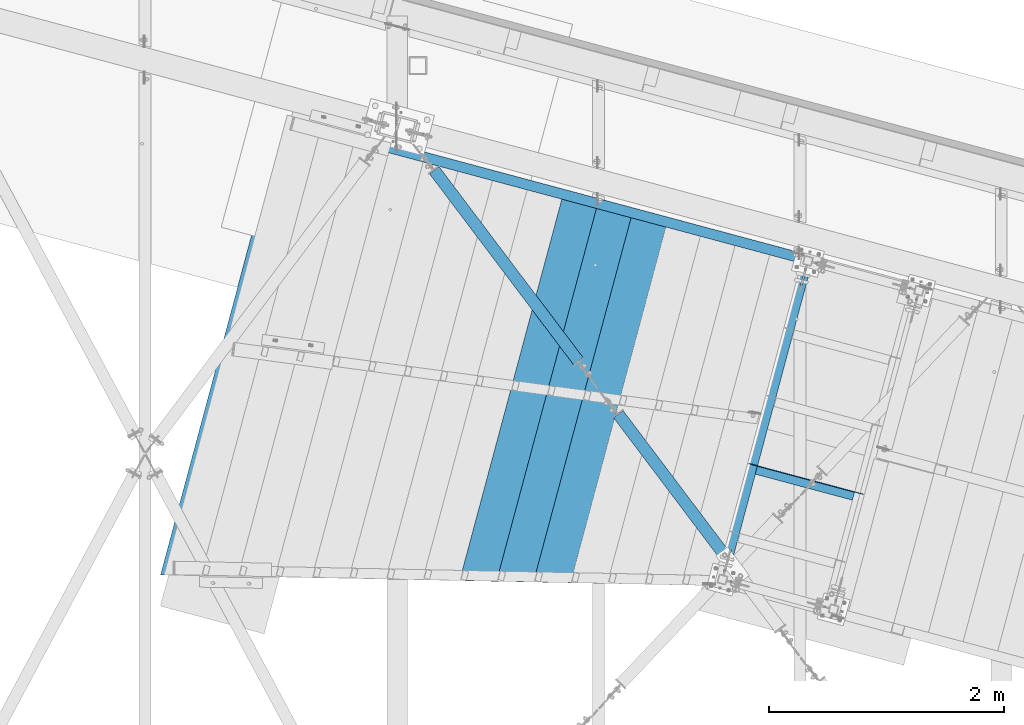
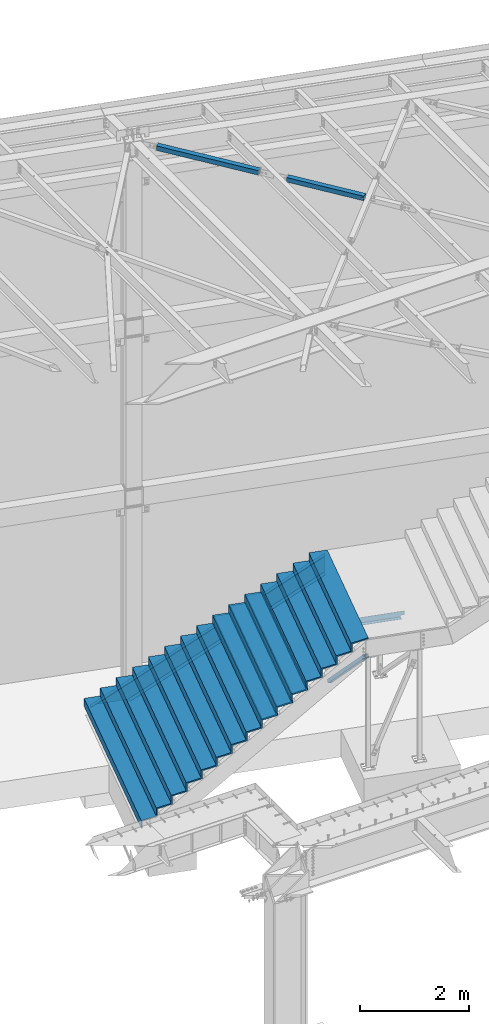
# One storey, part 1172 of 1763: 7 beams, 2 members, 6 elements without a shape of their own.
"""IFC2X3 building model written with IfcOpenShell, lengths in millimetres."""

from ifc_helpers import new_model, si_unit, frame, origin_with_axes, place, context, subcontext, project, spatial, faceted_brep, material, type_object, element, aggregate, save


model = new_model("IFC2X3")

# Units and contexts
model_context = context("Model", 3, precision=1e-05, world=origin_with_axes())
body_context = subcontext(model_context, "Body", "Model", "MODEL_VIEW")
ifc_project = project(units=[si_unit("LENGTHUNIT", "METRE", prefix="MILLI"), si_unit("AREAUNIT", "SQUARE_METRE"), si_unit("VOLUMEUNIT", "CUBIC_METRE"), si_unit("MASSUNIT", "GRAM", prefix="KILO"), si_unit("TIMEUNIT", "SECOND"), si_unit("PLANEANGLEUNIT", "RADIAN"), si_unit("SOLIDANGLEUNIT", "STERADIAN"), si_unit("THERMODYNAMICTEMPERATUREUNIT", "DEGREE_CELSIUS"), si_unit("LUMINOUSINTENSITYUNIT", "LUMEN")], contexts=[model_context])

# Site, building, storey
site_placement = place(None, origin_with_axes())
site = spatial("IfcSite", under=ifc_project, at=site_placement, CompositionType="ELEMENT")
building_placement = place(site_placement, origin_with_axes())
building = spatial("IfcBuilding", under=site, at=building_placement, Name="Undefined", CompositionType="ELEMENT")
storey_placement = place(building_placement, origin_with_axes())
storey = spatial("IfcBuildingStorey", under=building, at=storey_placement, Name="Undefined", CompositionType="ELEMENT", Elevation=0.0)

# Assembly, beam
assembly_1_placement = place(storey_placement, origin_with_axes())
assembly_1 = element("IfcElementAssembly", 1, at=assembly_1_placement, inside=storey, Name="FRAME", AssemblyPlace="NOTDEFINED", PredefinedType="RIGID_FRAME")
ifc_material_1 = material(Name="STEEL/A36")
beam_type_1 = type_object("IfcBeamType", Name="L5X3X1/4", PredefinedType="NOTDEFINED")
beam_1_placement = place(assembly_1_placement, frame((-28140.7287703231, 61498.0014634783, 2311.40000007908), z_axis=(0.0, 0.0, 1.0), x_axis=(0.965913267114843, -0.258865912030785, 0.0)))
beam_1 = element("IfcBeam", 2, at=beam_1_placement, type_object=beam_type_1, material=ifc_material_1, Name="ANGLE", ObjectType="L5X3X1/4", context=body_context, shape_type="Brep", body=[
    faceted_brep([(85.7250002993387, -38.0999999998603, -57.1500000000001), (92.0750017297105, -38.0999999998603, -63.499999957723), (935.037468048155, -38.0999999993292, -63.4999999958368), (941.387469479872, -38.0999999993292, -57.1500001000077), (92.0750019702682, 38.099999999984, -63.5), (935.037468215283, 38.1000000005079, -63.5), (949.227390314394, 31.7500000005311, -26.3667318659031), (949.22739032832, 38.1000000005151, -26.3667318659031), (954.087470019935, 38.1000000005224, -25.4000021055181), (954.087470006009, 31.7500000005311, -25.4000021055181), (945.107213654439, 31.7500000005239, -29.1197457287767), (945.107213668365, 38.1000000005079, -29.1197457287767), (942.354199608213, 31.7500000005239, -33.239922266207), (942.354199622132, 38.1000000005151, -33.239922266207), (941.387469631547, 31.7500000005239, -38.1000019147832), (941.387469645473, 38.1000000005079, -38.1000019147832), (941.387469631416, 31.7500000005239, -57.1500000000001), (941.387469645473, 38.1000000005079, -57.1500001197246), (85.7250005197857, 31.7499999999927, -57.1500000000001), (85.7250005398237, 38.0999999999694, -57.1500000397209), (85.7250005197711, 31.7499999999927, -38.1000018544964), (85.7250005398237, 38.0999999999694, -38.1000018544964), (84.7582705431123, 31.7499999999854, -33.2399222059203), (84.7582705631648, 38.0999999999694, -33.2399222059203), (82.0052564968937, 31.7499999999782, -29.1197456684899), (82.005256516939, 38.0999999999694, -29.1197456684899), (77.8850798369385, 31.7499999999854, -26.3667318056164), (77.8850798569911, 38.0999999999767, -26.3667318056164), (73.0250001453314, 31.7499999999854, -25.4000020452313), (73.0250001653767, 38.0999999999694, -25.4000020452313), (9.52500204597163, 31.7499999999345, -25.4000048709327), (9.52500206602417, 38.0999999999258, -25.4000048709327), (9.52500204597163, 31.7499999999345, 63.5), (9.52500206602417, 38.0999999999258, 63.5), (1017.58746719851, 31.7500000005748, 63.5), (1017.58746721857, 38.1000000005588, 63.5), (1017.58746721857, 38.1000000005588, -25.400004931219), (1017.58746719851, 31.7500000005748, -25.4000049312194)], [[[0, 1, 2, 3]], [[1, 4, 5, 2]], [[6, 7, 8, 9]], [[10, 11, 7, 6]], [[12, 13, 11, 10]], [[14, 15, 13, 12]], [[15, 14, 16, 17]], [[3, 2, 5, 17, 16]], [[18, 0, 3, 16]], [[1, 0, 18, 19, 4]], [[20, 21, 19, 18]], [[22, 23, 21, 20]], [[24, 25, 23, 22]], [[26, 27, 25, 24]], [[28, 29, 27, 26]], [[29, 28, 30, 31]], [[31, 30, 32, 33]], [[33, 32, 34, 35]], [[8, 7, 11, 13, 15, 17, 5, 4, 19, 21, 23, 25, 27, 29, 31, 33, 35, 36]], [[9, 8, 36, 37]], [[32, 30, 28, 26, 24, 22, 20, 18, 16, 14, 12, 10, 6, 9, 37, 34]], [[36, 35, 34, 37]]]),
])
aggregate(assembly_1, [beam_1])

assembly_2_placement = place(storey_placement, origin_with_axes())
assembly_2 = element("IfcElementAssembly", 3, at=assembly_2_placement, inside=storey, Name="H. BRACE", AssemblyPlace="NOTDEFINED", PredefinedType="RIGID_FRAME")
ifc_material_2 = material()
beam_type_2 = type_object("IfcBeamType", Name="HSS4X4X3/8", PredefinedType="NOTDEFINED")
beam_2_placement = place(assembly_2_placement, frame((-28260.020259811, 60661.9278012082, 12371.3875), z_axis=(0.0, 0.0, 1.0), x_axis=(-0.602242336837067, 0.798313326784057, 0.0)))
beam_2 = element("IfcBeam", 4, at=beam_2_placement, type_object=beam_type_2, material=ifc_material_2, Name="H. BRACE", ObjectType="HSS4X4X3/8", context=body_context, shape_type="Brep", body=[
    faceted_brep([(153.987500001618, -50.7999999998865, -6.35000000000036), (153.987500001676, -41.2749999998996, -6.35000000000036), (72.9619621178063, -41.2749999999178, -6.35000000000036), (72.9619621177844, -50.799999999901, -6.35000000000036), (153.987500001618, -50.7999999998865, 6.35000000000036), (153.987500001676, -41.2749999998996, 6.35000000000036), (72.9619621177844, -50.799999999901, 6.35000000000036), (72.9619621178063, -41.2749999999178, 6.35000000000036), (153.9875000022, 41.2749999999687, -6.35000000000036), (153.987500002258, 50.7999999999593, -6.35000000000036), (72.9619621180755, 50.7999999999411, -6.35000000000036), (72.9619621180464, 41.2749999999578, -6.35000000000036), (153.9875000022, 41.2749999999687, 6.35000000000036), (153.987500002258, 50.7999999999593, 6.35000000000036), (72.9619621180464, 41.2749999999578, 6.35000000000036), (72.9619621180755, 50.7999999999411, 6.35000000000036), (72.9619621178063, -41.2749999999178, 41.2749999999996), (72.9619621180464, 41.2749999999578, 41.2749999999996), (1612.38545285382, 41.2750000003216, 41.2749999999996), (1612.38545285357, -41.2749999995503, 41.2749999999996), (72.9619621180755, 50.7999999999411, 50.7999999999993), (1612.38545285384, 50.8000000003049, 50.7999999999993), (1612.38545285384, 50.8000000003049, -50.7999999999993), (72.9619621180755, 50.7999999999411, -50.7999999999993), (72.9619621177844, -50.799999999901, -50.7999999999993), (1612.38545285354, -50.7999999995336, -50.7999999999993), (72.9619621178063, -41.2749999999178, -41.2749999999996), (72.9619621180464, 41.2749999999578, -41.2749999999996), (1612.38545285357, -41.2749999995503, -41.2749999999996), (1612.38545285382, 41.2750000003216, -41.2749999999996), (1612.38545285354, -50.7999999995336, 50.7999999999993), (72.9619621177844, -50.799999999901, 50.7999999999993)], [[[0, 1, 2, 3]], [[4, 5, 1, 0]], [[6, 7, 5, 4]], [[8, 9, 10, 11]], [[12, 13, 9, 8]], [[14, 15, 13, 12]], [[16, 17, 18, 19]], [[20, 21, 22, 23, 10, 9, 13, 15]], [[24, 23, 22, 25]], [[26, 27, 11, 10, 23, 24, 3, 2]], [[16, 19, 28, 26, 2, 1, 5, 7]], [[27, 26, 28, 29]], [[30, 25, 22, 21], [19, 18, 29, 28]], [[20, 31, 30, 21]], [[3, 24, 25, 30, 31, 6, 4, 0]], [[31, 20, 15, 14, 17, 16, 7, 6]], [[11, 27, 29, 18, 17, 14, 12, 8]]]),
])
aggregate(assembly_2, [beam_2])

assembly_3_placement = place(storey_placement, origin_with_axes())
assembly_3 = element("IfcElementAssembly", 5, at=assembly_3_placement, inside=storey, Name="H. BRACE", AssemblyPlace="NOTDEFINED", PredefinedType="RIGID_FRAME")
beam_3_placement = place(assembly_3_placement, frame((-29400.5296174484, 62173.7508063884, 12371.3875), z_axis=(0.0, 0.0, 1.0), x_axis=(-0.602242336837067, 0.798313326784057, 0.0)))
beam_3 = element("IfcBeam", 6, at=beam_3_placement, type_object=beam_type_2, material=ifc_material_2, Name="H. BRACE", ObjectType="HSS4X4X3/8", context=body_context, shape_type="Brep", body=[
    faceted_brep([(281.53394529043, 41.2750000000051, -41.2749999999996), (281.533945290197, -41.2749999998668, -41.2749999999996), (2314.27412926893, -41.2749999993721, -41.2749999999996), (2314.27412926916, 41.2750000004889, -41.2749999999996), (281.533945290197, -41.2749999998668, 41.2749999999996), (2314.27412926893, -41.2749999993721, 41.2749999999996), (281.53394529043, 41.2750000000051, 41.2749999999996), (2314.27412926916, 41.2750000004889, 41.2749999999996), (281.533945290459, 50.7999999999884, -50.7999999999993), (281.533945290459, 50.7999999999884, 50.7999999999993), (2314.27412926919, 50.8000000004831, 50.7999999999993), (2314.27412926919, 50.8000000004831, -50.7999999999993), (281.533945290168, -50.7999999998501, 50.7999999999993), (2314.2741292689, -50.7999999993663, 50.7999999999993), (281.533945290168, -50.7999999998501, -50.7999999999993), (2314.2741292689, -50.7999999993663, -50.7999999999993)], [[[0, 1, 2, 3]], [[1, 4, 5, 2]], [[4, 6, 7, 5]], [[6, 0, 3, 7]], [[8, 9, 10, 11]], [[9, 12, 13, 10]], [[12, 14, 15, 13]], [[14, 8, 11, 15]], [[13, 15, 11, 10], [5, 7, 3, 2]], [[14, 12, 9, 8], [6, 4, 1, 0]]]),
])
aggregate(assembly_3, [beam_3])

# Assembly, member
assembly_4_placement = place(storey_placement, origin_with_axes())
assembly_4 = element("IfcElementAssembly", 7, at=assembly_4_placement, inside=storey, Name="STRINGER", AssemblyPlace="NOTDEFINED", PredefinedType="RIGID_FRAME")
member_type_1 = type_object("IfcMemberType", Name="C15X33.9", PredefinedType="NOTDEFINED")
member_1_placement = place(assembly_4_placement, frame((-27587.7807470832, 63251.1006457711, 2442.12511935681), z_axis=(0.486695708763338, -0.13043503320458, -0.863778900636194), x_axis=(-0.834335499956352, 0.223602912988303, -0.50387102597364)))
member_1 = element("IfcMember", 8, at=member_1_placement, type_object=member_type_1, material=ifc_material_1, Name="STRINGER", ObjectType="C15X33.9", context=body_context, shape_type="Brep", body=[
    faceted_brep([(-3.47911372537055, -42.8624999996318, -190.49999999988), (1.61578232239117, -42.8624999996682, -181.765892499887), (9.02115236152167, 33.3375000004598, -169.070972499881), (196.545886544038, 33.3374999991574, 152.399999999587), (201.016754472439, 33.3374999991283, 160.064345010509), (206.270620514268, 33.337499999092, 169.070972500009), (213.675990492862, -42.8625000011161, 181.765892499996), (218.770886540624, -42.8625000011598, 190.499999999993), (218.770886574683, 42.8624999990352, 190.500000000004), (-3.47911369131907, 42.8625000005704, -190.499999999876), (5154.39440455224, -42.8625000138563, -190.499999996955), (5139.42164885585, -42.8625000138345, -181.765892496969), (5117.65892881748, 33.3374999863663, -169.070972496982), (4537.98702379651, 33.3374999871448, 169.070972502464), (4516.22430388694, -42.8625000129832, 181.765892502437), (4501.25154819057, -42.8625000129759, 190.500000002419), (4501.2515481181, 42.8624999872263, 190.50000000243), (5154.39440447977, 42.8624999863387, -190.499999996948)], [[[0, 1, 2, 3, 4, 5, 6, 7, 8, 9]], [[1, 0, 10, 11]], [[2, 1, 11, 12]], [[5, 4, 3, 2, 12, 13]], [[6, 5, 13, 14]], [[7, 6, 14, 15]], [[8, 7, 15, 16]], [[9, 8, 16, 17]], [[15, 14, 13, 12, 11, 10, 17, 16]], [[0, 9, 17, 10]]]),
])

assembly_5_placement = place(storey_placement, origin_with_axes())
assembly_5 = element("IfcElementAssembly", 9, at=assembly_5_placement, inside=storey, Name="BRACE", AssemblyPlace="NOTDEFINED", PredefinedType="RIGID_FRAME")
member_type_2 = type_object("IfcMemberType", Name="HSS3X3X1/4", PredefinedType="NOTDEFINED")
member_2_placement = place(assembly_5_placement, frame((-27619.8997057889, 63251.3629503325, -254.000000011885), z_axis=(0.172357044040262, 0.643130363150223, 0.746107489148826), x_axis=(-0.193141324899824, -0.720675248626209, 0.66582551365466)))
member_2 = element("IfcMember", 10, at=member_2_placement, type_object=member_type_2, material=ifc_material_2, Name="BRACE", ObjectType="HSS3X3X1/4", context=body_context, shape_type="Brep", body=[
    faceted_brep([(3638.34189830234, 6.35008143950108, 38.1000000056956), (3431.96689252929, 6.35008143055165, 38.1000000053609), (3431.96689252927, 6.35006785710721, 31.7500000053769), (3638.34189830413, 6.35006786606391, 31.7500000057044), (3429.53685277032, 5.86671646916511, 38.1000000053609), (3429.53685277032, 5.86670289572794, 31.7500000053769), (3427.47676453633, 4.49020951885905, 38.1000000053609), (3427.47676453632, 4.49019594542187, 31.7500000053697), (3426.10025758616, 2.43012128475675, 38.1000000053609), (3426.10025758616, 2.43010771131958, 31.7500000053769), (3425.61689262495, 8.15303719718941e-05, 38.1000000053609), (3425.61689262494, 6.79569347994402e-05, 31.7500000053769), (3426.10025758628, -2.42995822866214, 38.1000000053609), (3426.10025758627, -2.42997180209932, 31.7500000053769), (3427.47676453656, -4.49004646272078, 38.1000000053682), (3427.47676453656, -4.49006003615068, 31.7500000053842), (3429.53685277066, -5.86655341291771, 38.1000000053755), (3429.53685277066, -5.86656698635488, 31.7500000053842), (3431.96689252968, -6.34991837416601, 38.1000000053828), (3431.96689252967, -6.34993194759591, 31.7500000053915), (3638.34189830262, -6.34991836979316, 38.1000000057174), (3638.34189830442, -6.34993194323761, 31.7500000057262), (3638.34189832208, 6.34993213164853, -31.749999994172), (3431.96689252918, 6.34993212276459, -31.7499999944994), (3431.96689252917, 6.34991854932741, -38.0999999944834), (3638.34189832388, 6.34991855821136, -38.099999994156), (3429.53685277022, 5.86656716137804, -31.7499999945067), (3429.53685277021, 5.86655358794087, -38.0999999944906), (3427.47676453622, 4.49006021107198, -31.7499999944994), (3427.47676453622, 4.4900466376348, -38.0999999944906), (3426.10025758607, 2.42997197696968, -31.7499999945067), (3426.10025758607, 2.42995840353979, -38.0999999944979), (3425.61689262484, -6.77774150972255e-05, -31.7499999945067), (3425.61689262484, -8.13508449937217e-05, -38.0999999944906), (3426.10025758619, -2.43010753644194, -31.7499999944994), (3426.10025758619, -2.43012110988639, -38.0999999944834), (3427.47676453647, -4.49019577050058, -31.7499999944921), (3427.47676453646, -4.49020934393775, -38.0999999944834), (3429.53685277056, -5.86670272070478, -31.7499999944921), (3429.53685277055, -5.86671629414195, -38.0999999944761), (3431.96689252958, -6.3500676819458, -31.7499999944848), (3431.96689252958, -6.35008125538297, -38.0999999944688), (3638.34189832237, -6.35006767763844, -31.7499999941574), (3638.34189832416, -6.35008125108288, -38.0999999941414), (118.968544799733, 31.7499999999782, 31.7500000000873), (118.968544810552, 31.7499999998836, -31.7499999997963), (3638.34189832152, 31.7499999957072, -31.7499999941938), (3638.34189830357, 31.7499999957945, 31.7500000056752), (3638.34189830497, -31.7500000043365, 31.750000005748), (118.968544766285, -31.7500000001601, 31.7500000001601), (118.968544779673, -6.34988402445742, 31.750000000131), (325.343551481637, -6.34992299378791, 31.7500000004584), (327.773591609155, -5.86655837652506, 31.7500000004584), (329.833680250282, -4.49005150574521, 31.7500000004657), (331.210187509649, -2.42996312424657, 31.7500000004657), (331.693552585297, 7.69121252233163e-05, 31.7500000004657), (331.210187737401, 2.43011673642468, 31.7500000004584), (329.833681093718, 4.49020482433843, 31.7500000004511), (327.773593263322, 5.86671185339219, 31.7500000004511), (325.343553869745, 6.35007715583924, 31.7500000004438), (118.968544786359, 6.35011579983984, 31.7500000001164), (118.96854477709, -31.7500000002474, -31.7499999997162), (3638.34189832293, -31.7500000044383, -31.7499999941283), (118.968544797164, 6.34999437355873, -31.7499999997672), (325.343553869468, 6.34995572941261, -31.7499999994325), (327.77359326306, 5.86659042696556, -31.7499999994252), (329.833681093449, 4.49008339790453, -31.7499999994179), (331.210187737131, 2.42999530999077, -31.7499999994179), (331.693552585028, -4.45143086835742e-05, -31.7499999994179), (331.210187509379, -2.43008455068048, -31.7499999994179), (329.833680250013, -4.49017293217912, -31.7499999994179), (327.773591608879, -5.86667980295897, -31.7499999994106), (325.343551481361, -6.35004442022182, -31.7499999994106), (118.96854479047, -6.35000545073126, -31.7499999997381), (118.968544798248, 6.34998223093135, -38.0999999997439), (325.343553869439, 6.34994358677068, -38.0999999994237), (327.773593263031, 5.86657828431635, -38.0999999994165), (329.83368109342, 4.49007125526259, -38.0999999994092), (331.210187737102, 2.42998316734884, -38.0999999994092), (331.693552584999, -5.66569578950293e-05, -38.0999999994092), (331.210187509358, -2.43009669332969, -38.0999999994019), (329.833680249983, -4.49018507482833, -38.0999999994019), (327.77359160885, -5.86669194560091, -38.0999999993946), (325.343551481332, -6.35005656287103, -38.0999999994092), (118.968544791562, -6.35001759335864, -38.0999999997366), (118.968544774827, -38.100000000275, -38.0999999997002), (118.968544761861, -38.1000000001659, 38.1000000001513), (118.968544778581, -6.34987188182276, 38.1000000001222), (325.343551481667, -6.34991085114598, 38.1000000004424), (327.773591609184, -5.86654623388313, 38.1000000004569), (329.833680250311, -4.49003936310328, 38.1000000004497), (331.210187509678, -2.42995098160463, 38.1000000004569), (331.693552585326, 8.90547671588138e-05, 38.1000000004497), (331.210187737423, 2.43012887907389, 38.1000000004424), (329.833681093754, 4.49021696698765, 38.1000000004424), (327.773593263351, 5.8667239960414, 38.1000000004351), (325.343553869774, 6.35008929848846, 38.1000000004351), (118.968544785283, 6.35012794246722, 38.1000000001004), (118.96854480201, 38.0999999999985, 38.100000000064), (118.968544814976, 38.0999999998967, -38.0999999997875), (3638.34189830163, 38.0999999958149, 38.1000000056592), (3638.34189832318, 38.099999995713, -38.0999999941996), (3638.34189832486, -38.1000000044587, -38.099999994105), (3638.34189830333, -38.1000000043496, 38.1000000057393)], [[[0, 1, 2, 3]], [[4, 5, 2, 1]], [[6, 7, 5, 4]], [[8, 9, 7, 6]], [[10, 11, 9, 8]], [[12, 13, 11, 10]], [[14, 15, 13, 12]], [[16, 17, 15, 14]], [[18, 19, 17, 16]], [[20, 21, 19, 18]], [[22, 23, 24, 25]], [[26, 27, 24, 23]], [[28, 29, 27, 26]], [[30, 31, 29, 28]], [[32, 33, 31, 30]], [[34, 35, 33, 32]], [[36, 37, 35, 34]], [[38, 39, 37, 36]], [[40, 41, 39, 38]], [[42, 43, 41, 40]], [[44, 45, 46, 47]], [[48, 49, 50, 51, 52, 53, 54, 55, 56, 57, 58, 59, 60, 44, 47, 3, 2, 5, 7, 9, 11, 13, 15, 17, 19, 21]], [[61, 49, 48, 62]], [[38, 36, 34, 32, 30, 28, 26, 23, 22, 46, 45, 63, 64, 65, 66, 67, 68, 69, 70, 71, 72, 73, 61, 62, 42, 40]], [[63, 74, 75, 64]], [[64, 75, 76, 65]], [[65, 76, 77, 66]], [[66, 77, 78, 67]], [[67, 78, 79, 68]], [[68, 79, 80, 69]], [[69, 80, 81, 70]], [[70, 81, 82, 71]], [[71, 82, 83, 72]], [[72, 83, 84, 73]], [[49, 61, 73, 84, 85, 86, 87, 50]], [[88, 51, 50, 87]], [[89, 52, 51, 88]], [[90, 53, 52, 89]], [[91, 54, 53, 90]], [[92, 55, 54, 91]], [[93, 56, 55, 92]], [[94, 57, 56, 93]], [[95, 58, 57, 94]], [[96, 59, 58, 95]], [[97, 60, 59, 96]], [[98, 99, 74, 63, 45, 44, 60, 97]], [[99, 98, 100, 101]], [[47, 46, 22, 25, 101, 100, 0, 3]], [[102, 85, 84, 83, 82, 81, 80, 79, 78, 77, 76, 75, 74, 99, 101, 25, 24, 27, 29, 31, 33, 35, 37, 39, 41, 43]], [[86, 85, 102, 103]], [[16, 14, 12, 10, 8, 6, 4, 1, 0, 100, 98, 97, 96, 95, 94, 93, 92, 91, 90, 89, 88, 87, 86, 103, 20, 18]], [[103, 102, 43, 42, 62, 48, 21, 20]]]),
])
aggregate(assembly_5, [member_2])

# Beam
beam_type_3 = type_object("IfcBeamType", PredefinedType="NOTDEFINED")
beam_4_placement = place(assembly_4_placement, frame((-29227.2085621771, 62031.3337576149, 1974.85009878302), z_axis=(-0.258865912030778, -0.965913267114844, 3.00823476209188e-08), x_axis=(0.0, 0.0, -1.0)))
beam_4 = element("IfcBeam", 11, at=beam_4_placement, type_object=beam_type_3, material=ifc_material_1, Name="BENT_PLATE", context=body_context, shape_type="Brep", body=[
    faceted_brep([(47.6250005251729, -309.562503402616, -1645.44349999938), (47.6250004588353, -1.58749999001157, -1645.44349999978), (2.11025508178864e-09, -1.58750000103464, -1645.44349999992), (1.37652023113333e-09, 1.58749999896827, -1645.44349999992), (50.8000004581395, 1.58750001073349, -1645.44349999977), (50.8000005244771, -306.387503401915, -1645.44349999938), (222.250000065325, -306.387503364131, -1645.4434999989), (222.250000066024, -309.562503364126, -1645.44349999889), (222.250000062706, -309.562503359819, 1645.44350000095), (47.6250005218553, -309.562503398403, 1645.44350000045), (47.6250004533019, -1.5874999880034, 1569.38377828299), (-1.29671207105275e-09, -1.58749999902648, 1569.38377971571), (-2.02931005333085e-09, 1.58750000097643, 1568.59909614019), (50.8000004526075, 1.58750001274166, 1568.59909461196), (50.8000005211602, -306.387503397702, 1644.71340228045), (222.250000062008, -306.387503359823, 1644.71339712312)], [[[0, 1, 2, 3, 4, 5, 6, 7]], [[0, 7, 8, 9]], [[1, 0, 9, 10]], [[2, 1, 10, 11]], [[3, 2, 11, 12]], [[4, 3, 12, 13]], [[5, 4, 13, 14]], [[6, 5, 14, 15]], [[7, 6, 15, 8]], [[14, 13, 12, 11, 10, 9, 8, 15]]]),
])

beam_5_placement = place(assembly_4_placement, frame((-29531.276349829, 62074.2012569294, 1797.05005108784), z_axis=(-0.258865912030778, -0.965913267114844, 3.00823476209188e-08), x_axis=(0.0, 0.0, -1.0)))
beam_5 = element("IfcBeam", 12, at=beam_5_placement, type_object=beam_type_3, material=ifc_material_1, Name="BENT_PLATE", context=body_context, shape_type="Brep", body=[
    faceted_brep([(47.6250005321042, -309.562503398447, 1682.75000000046), (47.6250005358797, -309.562503402529, -1682.74999999937), (222.250000066042, -309.562503364163, -1682.74999999887), (222.250000062553, -309.562503359753, 1682.75000000096), (47.6250004695416, -1.58749998999701, -1682.74999999977), (2.27532837016042e-09, -1.58750000105647, -1682.74999999991), (1.54000190377701e-09, 1.58749999893917, -1682.74999999992), (50.8000004688454, 1.58750001073349, -1682.74999999977), (50.8000005351837, -306.387503401827, -1682.74999999937), (222.250000065343, -306.38750336416, -1682.74999999887), (222.250000061854, -306.387503359758, 1682.75000000096), (50.8000005314082, -306.387503397753, 1682.75000000046), (47.6250005314084, -306.441974500784, 1682.75000000045), (47.6250004635576, -1.58749998793792, 1607.40691367775), (-1.4547367754858e-09, -1.58749999900465, 1607.40691511048), (-2.188926373492e-09, 1.58750000099826, 1606.62223153495), (50.800000462863, 1.58750001279259, 1606.62223000672)], [[[0, 1, 2, 3]], [[1, 4, 5, 6, 7, 8, 9, 2]], [[3, 2, 9, 10]], [[8, 11, 10, 9]], [[0, 3, 10, 11, 12]], [[4, 1, 0, 12, 13]], [[5, 4, 13, 14]], [[6, 5, 14, 15]], [[7, 6, 15, 16]], [[8, 7, 16, 11]], [[15, 14, 13, 12, 11, 16]]]),
])

beam_6_placement = place(assembly_4_placement, frame((-29835.5495373344, 62116.3022989467, 1619.25000341607), z_axis=(-0.258865912030778, -0.965913267114844, 3.00823476209188e-08), x_axis=(0.0, 0.0, -1.0)))
beam_6 = element("IfcBeam", 13, at=beam_6_placement, type_object=beam_type_3, material=ifc_material_1, Name="BENT_PLATE", context=body_context, shape_type="Brep", body=[
    faceted_brep([(47.6250005457207, -309.562503402762, -1720.84999999939), (47.625000479457, -1.58749999005522, -1720.84999999979), (2.18983586819377e-09, -1.58750000107102, -1720.84999999992), (1.45678313856479e-09, 1.58749999892461, -1720.84999999993), (50.8000004787609, 1.58750001068256, -1720.84999999977), (50.8000005450244, -306.387503402053, -1720.84999999938), (222.250000065313, -306.387503364203, -1720.84999999889), (222.250000066012, -309.562503364206, -1720.84999999888), (222.250000062445, -309.56250335971, 1720.85000000094), (47.6250005422507, -309.562503398236, 1720.85000000044), (47.6250004736246, -1.58749998794519, 1644.63654400603), (-1.37652023113333e-09, -1.58749999896827, 1644.63654543873), (-2.10889083973598e-09, 1.58750000103464, 1643.85186186321), (50.8000004729299, 1.58750001278531, 1643.85186033499), (50.8000005415556, -306.387503397535, 1719.96616800346), (222.250000061747, -306.387503359707, 1719.96616284617)], [[[0, 1, 2, 3, 4, 5, 6, 7]], [[0, 7, 8, 9]], [[1, 0, 9, 10]], [[2, 1, 10, 11]], [[3, 2, 11, 12]], [[4, 3, 12, 13]], [[5, 4, 13, 14]], [[6, 5, 14, 15]], [[7, 6, 15, 8]], [[14, 13, 12, 11, 10, 9, 8, 15]]]),
])

aggregate(assembly_4, [member_1, beam_4, beam_5, beam_6])

# Assembly, beam
assembly_6_placement = place(storey_placement, origin_with_axes())
assembly_6 = element("IfcElementAssembly", 14, at=assembly_6_placement, inside=storey, Name="TILE ON CEMENT BOARD", AssemblyPlace="NOTDEFINED", PredefinedType="REINFORCEMENT_UNIT")
ifc_material_3 = material(Name="CONCRETE/3000")
beam_type_4 = type_object("IfcBeamType", PredefinedType="NOTDEFINED")
beam_7_placement = place(assembly_6_placement, frame((-32450.8167579685, 63028.349947543, -4.54747350886464e-13), z_axis=(-0.258865912030778, -0.965913267114844, 3.00823476209188e-08), x_axis=(0.0, 0.0, 1.0)))
beam_7 = element("IfcBeam", 15, at=beam_7_placement, type_object=beam_type_4, material=ifc_material_3, Name="TILE ON CEMENT BOARD", context=body_context, shape_type="Brep", body=[
    faceted_brep([(2489.19995117187, -3948.11250233436, 1555.11270283898), (2311.39990234374, -3948.11250233436, 1555.11270283898), (2311.39990234374, -3643.31244764445, 1630.44233960539), (2133.60009765624, -3643.31244764445, 1630.44233960539), (2133.60009765624, -3338.51242455436, 1705.77196856208), (1955.80004882812, -3338.51242455434, 1705.77196856208), (1955.8000488281, -3033.71262148304, 1781.10154314234), (1777.99999999999, -3033.71262148305, 1781.10154314234), (1778.00000000002, -2728.91258259304, 1856.43117600388), (1600.19995117187, -2728.91258259304, 1856.43117600388), (1600.19995117187, -2424.11254370303, 1931.76080886543), (1422.40002441406, -2424.11254370303, 1931.76080886543), (1422.40002441406, -2119.31250481304, 2007.09044172698), (1244.59997558593, -2119.31250481304, 2007.09044172698), (1244.59997558593, -1814.51247382301, 2082.42007263609), (1066.80004882812, -1814.51247382301, 2082.42007263609), (1066.80004882816, -1509.7125607423, 2157.74967440456), (888.999999999994, -1509.71256074234, 2157.74967440455), (888.999999999994, -1204.9125218523, 2233.07930726611), (711.200012207025, -1204.91252185227, 2233.07930726612), (711.200012206903, -900.112486912287, 2308.40893915144), (533.400024414057, -900.112486912221, 2308.40893915146), (533.400024414134, -595.312510926939, 2383.73855646644), (355.60000610351, -595.312510926989, 2383.73855646644), (355.60000610351, -290.512505464263, 2459.06818106661), (177.800003051752, -290.512505464263, 2459.06818106661), (177.800003051752, 14.287499998507, 2534.44349999986), (-7.01610186468113e-12, 14.2874999984197, 2534.44349999986), (7.01610186468113e-12, -14.2875000015774, 2527.33565348709), (149.225003051752, -14.2875000014901, 2527.33565348711), (149.225003051752, -319.087505464253, 2452.00602888693), (327.02500610351, -319.087505464253, 2452.00602888693), (327.02500610351, -623.887510926979, 2376.67640428674), (504.825024414134, -623.887510926936, 2376.67640428675), (504.825024414057, -928.687486912211, 2301.34678697176), (682.625012206904, -928.687486912277, 2301.34678697174), (682.625012207025, -1233.48752185226, 2226.01715508643), (860.424999999994, -1233.48752185229, 2226.01715508642), (860.424999999994, -1538.28756074234, 2150.68752222486), (1038.22504882816, -1538.28756074229, 2150.68752222486), (1038.22504882812, -1843.087473823, 2075.35792045639), (1216.02497558593, -1843.087473823, 2075.35792045639), (1216.02497558593, -2147.88750481304, 2000.02828954728), (1393.82502441406, -2147.88750481304, 2000.02828954728), (1393.82502441406, -2452.68754370302, 1924.69865668574), (1571.62495117187, -2452.68754370302, 1924.69865668574), (1571.62495117187, -2757.48758259303, 1849.36902382419), (1749.42500000002, -2757.48758259303, 1849.36902382419), (1749.42499999999, -3062.28762148305, 1774.03939096264), (1927.2250488281, -3062.28762148302, 1774.03939096264), (1927.22504882812, -3367.08742455433, 1698.70981638238), (2105.02509765624, -3367.08742455435, 1698.70981638238), (2105.02509765624, -3671.88744764445, 1623.3801874257), (2282.82490234374, -3671.88744764445, 1623.3801874257), (2282.82490234374, -3976.68750233435, 1548.0505506593), (2460.62495117187, -3976.68750233435, 1548.0505506593), (2460.62495117187, -4281.48750962451, 1472.72092560747), (2638.42499999999, -4281.48750962451, 1472.72092560747), (2638.42499999999, -4602.16255139558, 1393.46787415627), (2666.99999999999, -4602.16255139558, 1393.46787415627), (2666.99999999999, -4252.91250962451, 1479.78307778716), (2489.19995117187, -4252.91250962451, 1479.78307778716), (2666.99999999999, -4602.16255139376, -1516.96002721654), (2666.99999999999, -4252.91250962263, -1516.95507801481), (2489.19995117187, -4252.91250962263, -1516.95507801481), (2489.19995117187, -3948.11250233243, -1516.9507587119), (2311.39990234374, -3948.11250233243, -1516.9507587119), (2311.39990234374, -3643.31244764248, -1516.94643940832), (2133.60009765624, -3643.31244764248, -1516.94643940832), (2133.60009765624, -3338.51242455234, -1516.94212010517), (1955.80004882812, -3338.51242455236, -1516.94212010517), (1955.80004882814, -3033.71262148097, -1516.93780080516), (1777.99999999999, -3033.71262148095, -1516.93780080516), (1777.99999999998, -2728.91258259092, -1516.9334815018), (1600.19995117187, -2728.91258259092, -1516.9334815018), (1600.19995117187, -2424.11254370087, -1516.92916219844), (1422.40002441406, -2424.11254370087, -1516.92916219844), (1422.40002441406, -2119.31250481083, -1516.92484289508), (1244.59997558593, -2119.31250481083, -1516.92484289508), (1244.59997558593, -1814.51247382075, -1516.92052359183), (1066.80004882812, -1814.51247382075, -1516.92052359183), (1066.80004882809, -1509.71256074, -1516.91620429025), (888.999999999994, -1509.71256073996, -1516.91620429025), (888.999999999994, -1204.91252184995, -1516.9118849869), (711.200012207025, -1204.91252184998, -1516.9118849869), (711.200012207106, -900.112486909886, -1516.90756568359), (533.400024414057, -900.112486909929, -1516.90756568359), (533.400024414008, -595.312510924501, -1516.90324638112), (355.60000610351, -595.312510924472, -1516.90324638112), (355.60000610351, -290.512505461775, -1516.89892707824), (177.800003051752, -290.512505461775, -1516.89892707824), (177.800003051752, 14.2875000010463, -1516.89460777536), (-7.01610186468113e-12, 14.2875000009517, -1516.89460777535), (7.01610186468113e-12, -14.2874999990454, -1516.89501271), (149.225003051752, -14.2874999989726, -1516.89501270999), (149.225003051752, -319.087505461772, -1516.89933201287), (327.02500610351, -319.087505461772, -1516.89933201287), (327.02500610351, -623.887510924469, -1516.90365131576), (504.825024414008, -623.887510924498, -1516.90365131576), (504.825024414057, -928.687486909934, -1516.90797061822), (682.625012207106, -928.687486909883, -1516.90797061823), (682.625012207025, -1233.48752184997, -1516.91228992154), (860.424999999994, -1233.48752184995, -1516.91228992154), (860.424999999994, -1538.28756073998, -1516.9166092249), (1038.22504882809, -1538.28756074, -1516.9166092249), (1038.22504882812, -1843.08747382075, -1516.92092852647), (1216.02497558593, -1843.08747382075, -1516.92092852647), (1216.02497558593, -2147.88750481083, -1516.92524782972), (1393.82502441406, -2147.88750481083, -1516.92524782972), (1393.82502441406, -2452.68754370087, -1516.92956713308), (1571.62495117187, -2452.68754370087, -1516.92956713308), (1571.62495117187, -2757.48758259093, -1516.93388643644), (1749.42499999998, -2757.48758259093, -1516.93388643644), (1749.42499999999, -3062.28762148095, -1516.9382057398), (1927.22504882814, -3062.28762148097, -1516.9382057398), (1927.22504882812, -3367.08742455236, -1516.94252503982), (2105.02509765624, -3367.08742455234, -1516.94252503981), (2105.02509765624, -3671.88744764248, -1516.94684434295), (2282.82490234374, -3671.88744764248, -1516.94684434295), (2282.82490234374, -3976.68750233243, -1516.95116364653), (2460.62495117187, -3976.68750233243, -1516.95116364653), (2460.62495117187, -4281.48750962263, -1516.95548294944), (2638.42499999999, -4281.48750962263, -1516.95548294944), (2638.42499999999, -4602.16255139376, -1516.96002721654)], [[[0, 1, 2, 3, 4, 5, 6, 7, 8, 9, 10, 11, 12, 13, 14, 15, 16, 17, 18, 19, 20, 21, 22, 23, 24, 25, 26, 27, 28, 29, 30, 31, 32, 33, 34, 35, 36, 37, 38, 39, 40, 41, 42, 43, 44, 45, 46, 47, 48, 49, 50, 51, 52, 53, 54, 55, 56, 57, 58, 59, 60, 61]], [[60, 59, 62, 63]], [[61, 60, 63, 64]], [[0, 61, 64, 65]], [[1, 0, 65, 66]], [[2, 1, 66, 67]], [[3, 2, 67, 68]], [[4, 3, 68, 69]], [[5, 4, 69, 70]], [[6, 5, 70, 71]], [[7, 6, 71, 72]], [[8, 7, 72, 73]], [[9, 8, 73, 74]], [[10, 9, 74, 75]], [[11, 10, 75, 76]], [[12, 11, 76, 77]], [[13, 12, 77, 78]], [[14, 13, 78, 79]], [[15, 14, 79, 80]], [[16, 15, 80, 81]], [[17, 16, 81, 82]], [[18, 17, 82, 83]], [[19, 18, 83, 84]], [[20, 19, 84, 85]], [[21, 20, 85, 86]], [[22, 21, 86, 87]], [[23, 22, 87, 88]], [[24, 23, 88, 89]], [[25, 24, 89, 90]], [[26, 25, 90, 91]], [[27, 26, 91, 92]], [[28, 27, 92, 93]], [[29, 28, 93, 94]], [[30, 29, 94, 95]], [[31, 30, 95, 96]], [[32, 31, 96, 97]], [[33, 32, 97, 98]], [[34, 33, 98, 99]], [[35, 34, 99, 100]], [[36, 35, 100, 101]], [[37, 36, 101, 102]], [[38, 37, 102, 103]], [[39, 38, 103, 104]], [[40, 39, 104, 105]], [[41, 40, 105, 106]], [[42, 41, 106, 107]], [[43, 42, 107, 108]], [[44, 43, 108, 109]], [[45, 44, 109, 110]], [[46, 45, 110, 111]], [[47, 46, 111, 112]], [[48, 47, 112, 113]], [[49, 48, 113, 114]], [[50, 49, 114, 115]], [[51, 50, 115, 116]], [[52, 51, 116, 117]], [[53, 52, 117, 118]], [[54, 53, 118, 119]], [[55, 54, 119, 120]], [[56, 55, 120, 121]], [[57, 56, 121, 122]], [[58, 57, 122, 123]], [[59, 58, 123, 62]], [[122, 121, 120, 119, 118, 117, 116, 115, 114, 113, 112, 111, 110, 109, 108, 107, 106, 105, 104, 103, 102, 101, 100, 99, 98, 97, 96, 95, 94, 93, 92, 91, 90, 89, 88, 87, 86, 85, 84, 83, 82, 81, 80, 79, 78, 77, 76, 75, 74, 73, 72, 71, 70, 69, 68, 67, 66, 65, 64, 63, 62, 123]]]),
])
aggregate(assembly_6, [beam_7])

save(model, "model.ifc")
